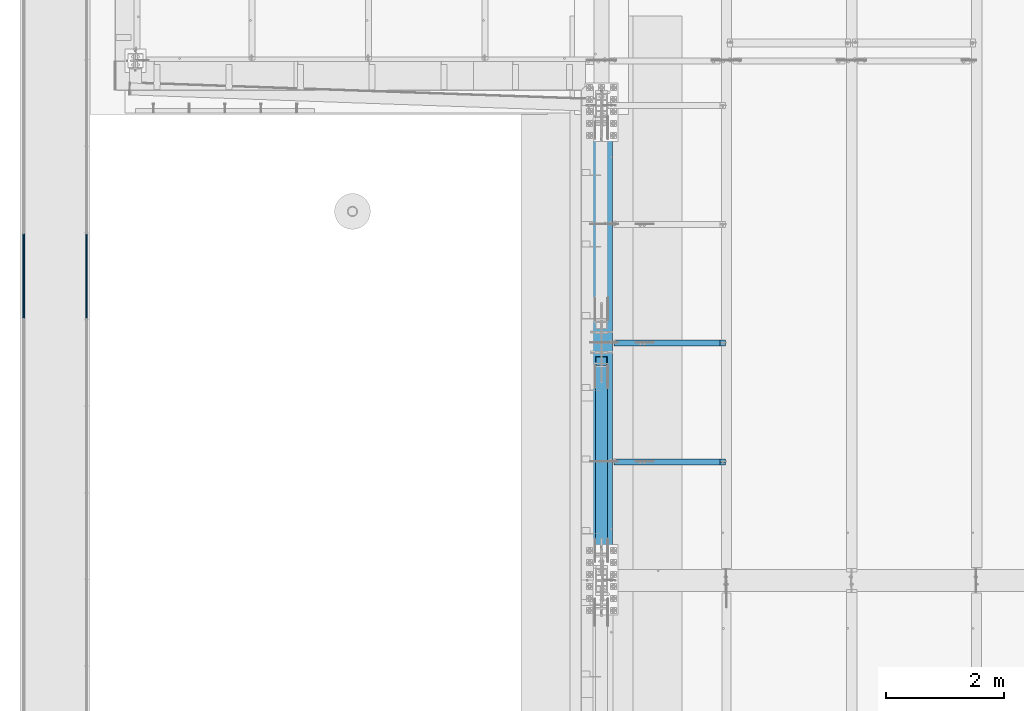
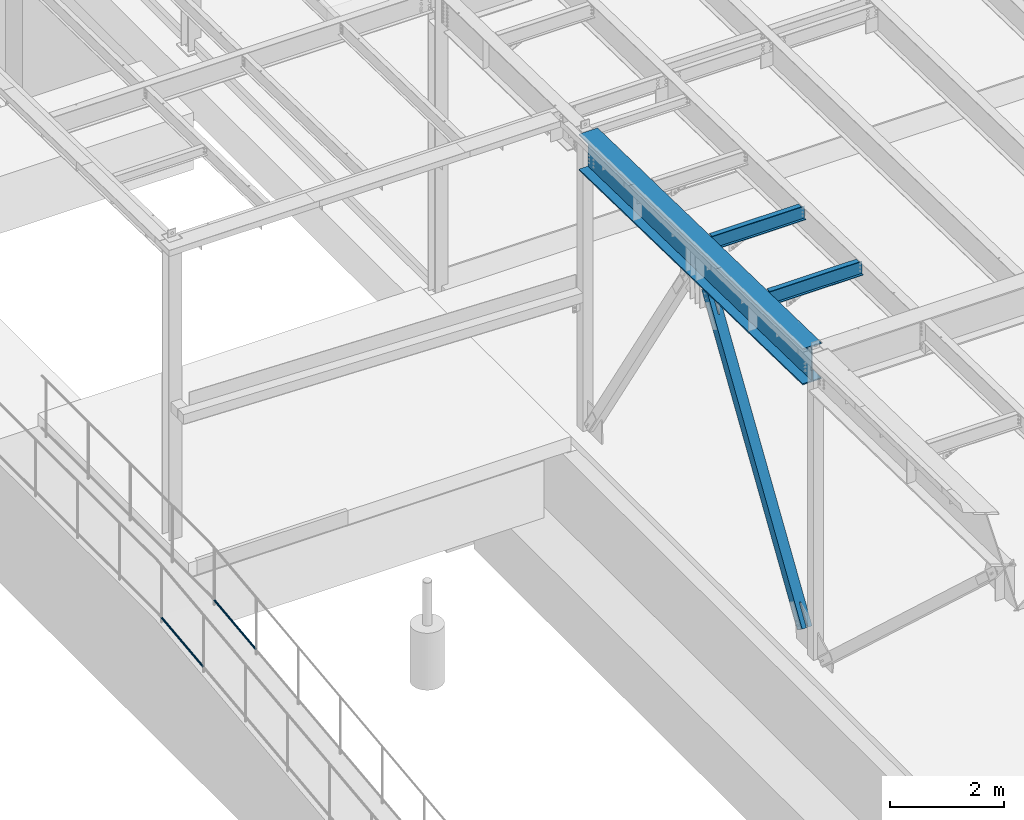
# One storey, part 1044 of 1763: 5 beams, 1 member, 6 elements without a shape of their own.
"""IFC2X3 building model written with IfcOpenShell, lengths in millimetres."""

from ifc_helpers import new_model, si_unit, frame, origin_with_axes, place, context, subcontext, project, spatial, faceted_brep, material, type_object, element, aggregate, save


model = new_model("IFC2X3")

# Units and contexts
model_context = context("Model", 3, precision=1e-05, world=origin_with_axes())
body_context = subcontext(model_context, "Body", "Model", "MODEL_VIEW")
ifc_project = project(units=[si_unit("LENGTHUNIT", "METRE", prefix="MILLI"), si_unit("AREAUNIT", "SQUARE_METRE"), si_unit("VOLUMEUNIT", "CUBIC_METRE"), si_unit("MASSUNIT", "GRAM", prefix="KILO"), si_unit("TIMEUNIT", "SECOND"), si_unit("PLANEANGLEUNIT", "RADIAN"), si_unit("SOLIDANGLEUNIT", "STERADIAN"), si_unit("THERMODYNAMICTEMPERATUREUNIT", "DEGREE_CELSIUS"), si_unit("LUMINOUSINTENSITYUNIT", "LUMEN")], contexts=[model_context])

# Site, building, storey
site_placement = place(None, origin_with_axes())
site = spatial("IfcSite", under=ifc_project, at=site_placement, CompositionType="ELEMENT")
building_placement = place(site_placement, origin_with_axes())
building = spatial("IfcBuilding", under=site, at=building_placement, Name="Undefined", CompositionType="ELEMENT")
storey_placement = place(building_placement, origin_with_axes())
storey = spatial("IfcBuildingStorey", under=building, at=storey_placement, Name="Undefined", CompositionType="ELEMENT", Elevation=0.0)

# Assembly, beam
assembly_1_placement = place(storey_placement, origin_with_axes())
assembly_1 = element("IfcElementAssembly", 1, at=assembly_1_placement, inside=storey, Name="GUARDRAIL", AssemblyPlace="NOTDEFINED", PredefinedType="RIGID_FRAME")
ifc_material_1 = material(Name="STEEL/A513")
beam_type_1 = type_object("IfcBeamType", PredefinedType="NOTDEFINED")
beam_1_placement = place(assembly_1_placement, frame((-97200.6527017878, 4895.63786635489, 5845.27590391864), z_axis=(0.0, -0.114062593029902, 0.993473565260443), x_axis=(0.0, 0.993473565260443, 0.114062593029902)))
beam_1 = element("IfcBeam", 2, at=beam_1_placement, type_object=beam_type_1, material=ifc_material_1, Name="GUARDRAIL", context=body_context, shape_type="Brep", body=[
    faceted_brep([(1468.16665642951, -9.52499999999418, 16.4977839425555), (1467.58900470802, -9.52499999999418, 11.4667123804174), (1467.30376971339, -7.68349999999919, 13.3082123804179), (1465.46783960526, 0.0, 15.3670000004613), (1465.89071001447, 0.0, 19.0500000004622), (1467.3037697134, 7.68349999999919, 13.308212380417), (1467.58900470802, 9.52499999999418, 11.4667123804174), (1468.16665642951, 9.52499999999418, 16.4977839425555), (1482.87860532686, 19.0500000000029, 4.66570782009512e-10), (1474.38465767071, 16.4977839420899, 9.52500000046439), (1472.19739693342, 16.4977839420899, -9.52499999953761), (1470.96269582906, 13.3082123799541, 7.68350000046303), (1472.15281425492, 15.3669999999984, 4.6293280320242e-10), (1469.19830550098, 13.3082123799541, -7.68349999953807), (1464.95586142462, 9.52499999999418, -11.4667123794952), (1464.37820970313, 9.52499999999418, -16.4977839416342), (1464.24775602078, 7.68349999999919, -13.3082123794957), (1461.9390589491, 0.0, -15.3669999995409), (1461.51618853989, 0.0, -19.0499999995409), (1464.95586142462, -9.52499999999418, -11.4667123794952), (1464.37820970313, -9.52499999999418, -16.4977839416342), (1464.24775602078, -7.68349999999919, -13.3082123794948), (1482.87860532695, -19.0500000000029, 4.55656845588237e-10), (1472.19739693342, -16.4977839420899, -9.52499999953761), (1474.38465767071, -16.4977839420899, 9.52500000046439), (1469.19830550097, -13.3082123799541, -7.68349999953807), (1472.15281425491, -15.3669999999984, 4.6293280320242e-10), (1470.96269582905, -13.3082123799541, 7.68350000046303), (8.49463121237, -16.4977839420899, -9.52499999999782), (14.7126324911599, -9.52499999999418, -16.4977839420899), (0.00068350478454704, 19.0500000000029, 0.0), (8.49463121237, 16.4977839420899, -9.52499999999782), (10.6818918337324, 16.4977839420899, 9.52500000000418), (18.5010790167537, 9.52499999999418, 16.4977839421008), (21.3631001626848, 0.0, 19.0500000000075), (14.7126324911599, 9.52499999999418, -16.4977839420899), (16.9885789199607, 0.0, -19.0499999999956), (17.4114493067575, 0.0, -15.3669999999956), (15.2902841820321, -9.52499999999418, -11.4667123799509), (15.575519187561, -7.68349999999919, -13.3082123799513), (15.575519187561, 7.68349999999919, -13.3082123799513), (15.2902841820321, 9.52499999999418, -11.4667123799509), (11.9165930406441, 13.3082123799541, -7.68349999999646), (10.7264745694495, 15.3669999999984, 4.54747350886464e-12), (13.6809832752053, 13.3082123799541, 7.68350000000555), (17.923427325881, 9.52499999999418, 11.4667123799609), (18.631532718199, 7.68349999999919, 13.3082123799622), (20.9402297758882, 0.0, 15.3670000000075), (18.631532718199, -7.68349999999919, 13.3082123799622), (17.923427325881, -9.52499999999418, 11.4667123799609), (18.5010790167537, -9.52499999999418, 16.4977839421008), (10.6818918337324, -16.4977839420899, 9.52500000000418), (0.00068350478454704, -19.0500000000029, 0.0), (13.6809832752053, -13.3082123799541, 7.68350000000555), (10.7264745694495, -15.3669999999984, 4.54747350886464e-12), (11.9165930406441, -13.3082123799541, -7.68349999999646)], [[[0, 1, 2, 3, 4]], [[4, 3, 5, 6, 7]], [[8, 9, 10]], [[7, 6, 11, 12, 13, 14, 15, 10, 9]], [[16, 17, 18, 15, 14]], [[19, 20, 18, 17, 21]], [[22, 23, 24]], [[24, 23, 20, 19, 25, 26, 27, 1, 0]], [[28, 29, 20, 23]], [[30, 31, 32]], [[33, 34, 4, 7]], [[32, 33, 7, 9]], [[30, 32, 9, 8]], [[31, 30, 8, 10]], [[35, 31, 10, 15]], [[36, 35, 15, 18]], [[29, 36, 18, 20]], [[37, 36, 29, 38, 39]], [[40, 41, 35, 36, 37]], [[32, 31, 35, 41, 42, 43, 44, 45, 33]], [[33, 45, 46, 47, 34]], [[34, 47, 48, 49, 50]], [[34, 50, 0, 4]], [[50, 51, 24, 0]], [[51, 52, 22, 24]], [[52, 28, 23, 22]], [[51, 28, 52]], [[50, 49, 53, 54, 55, 38, 29, 28, 51]], [[55, 54, 26, 25]], [[21, 39, 38, 55, 25, 19]], [[37, 39, 21, 17]], [[40, 37, 17, 16]], [[42, 41, 40, 16, 14, 13]], [[43, 42, 13, 12]], [[44, 43, 12, 11]], [[5, 46, 45, 44, 11, 6]], [[47, 46, 5, 3]], [[48, 47, 3, 2]], [[53, 49, 48, 2, 1, 27]], [[54, 53, 27, 26]]]),
])
aggregate(assembly_1, [beam_1])

assembly_2_placement = place(storey_placement, origin_with_axes())
assembly_2 = element("IfcElementAssembly", 3, at=assembly_2_placement, inside=storey, Name="GUARDRAIL", AssemblyPlace="NOTDEFINED", PredefinedType="RIGID_FRAME")
beam_2_placement = place(assembly_2_placement, frame((-96133.8527017878, 4895.63786635489, 5845.27590391864), z_axis=(0.0, -0.114062593029902, 0.993473565260443), x_axis=(0.0, 0.993473565260443, 0.114062593029902)))
beam_2 = element("IfcBeam", 4, at=beam_2_placement, type_object=beam_type_1, material=ifc_material_1, Name="GUARDRAIL", context=body_context, shape_type="Brep", body=[
    faceted_brep([(1468.16665642951, -9.52499999999418, 16.4977839425555), (1467.58900470802, -9.52499999999418, 11.4667123804174), (1467.30376971339, -7.68349999999919, 13.3082123804179), (1465.46783960526, 0.0, 15.3670000004613), (1465.89071001447, 0.0, 19.0500000004622), (1467.3037697134, 7.68349999999919, 13.308212380417), (1467.58900470802, 9.52499999999418, 11.4667123804174), (1468.16665642951, 9.52499999999418, 16.4977839425555), (1482.87860532686, 19.0500000000029, 4.66570782009512e-10), (1474.38465767071, 16.4977839420899, 9.52500000046439), (1472.19739693342, 16.4977839420899, -9.52499999953761), (1470.96269582906, 13.3082123799541, 7.68350000046303), (1472.15281425492, 15.3669999999984, 4.6293280320242e-10), (1469.19830550098, 13.3082123799541, -7.68349999953807), (1464.95586142462, 9.52499999999418, -11.4667123794952), (1464.37820970313, 9.52499999999418, -16.4977839416342), (1464.24775602078, 7.68349999999919, -13.3082123794957), (1461.9390589491, 0.0, -15.3669999995409), (1461.51618853989, 0.0, -19.0499999995409), (1464.95586142462, -9.52499999999418, -11.4667123794952), (1464.37820970313, -9.52499999999418, -16.4977839416342), (1464.24775602078, -7.68349999999919, -13.3082123794948), (1482.87860532695, -19.0500000000029, 4.55656845588237e-10), (1472.19739693342, -16.4977839420899, -9.52499999953761), (1474.38465767071, -16.4977839420899, 9.52500000046439), (1469.19830550097, -13.3082123799541, -7.68349999953807), (1472.15281425491, -15.3669999999984, 4.6293280320242e-10), (1470.96269582905, -13.3082123799541, 7.68350000046303), (8.49463121237, -16.4977839420899, -9.52499999999782), (14.7126324911599, -9.52499999999418, -16.4977839420899), (0.00068350478454704, 19.0500000000029, 0.0), (8.49463121237, 16.4977839420899, -9.52499999999782), (10.6818918337324, 16.4977839420899, 9.52500000000418), (18.5010790167537, 9.52499999999418, 16.4977839421008), (21.3631001626848, 0.0, 19.0500000000075), (14.7126324911599, 9.52499999999418, -16.4977839420899), (16.9885789199607, 0.0, -19.0499999999956), (17.4114493067575, 0.0, -15.3669999999956), (15.2902841820321, -9.52499999999418, -11.4667123799509), (15.575519187561, -7.68349999999919, -13.3082123799513), (15.575519187561, 7.68349999999919, -13.3082123799513), (15.2902841820321, 9.52499999999418, -11.4667123799509), (11.9165930406441, 13.3082123799541, -7.68349999999646), (10.7264745694495, 15.3669999999984, 4.54747350886464e-12), (13.6809832752053, 13.3082123799541, 7.68350000000555), (17.923427325881, 9.52499999999418, 11.4667123799609), (18.631532718199, 7.68349999999919, 13.3082123799622), (20.9402297758882, 0.0, 15.3670000000075), (18.631532718199, -7.68349999999919, 13.3082123799622), (17.923427325881, -9.52499999999418, 11.4667123799609), (18.5010790167537, -9.52499999999418, 16.4977839421008), (10.6818918337324, -16.4977839420899, 9.52500000000418), (0.00068350478454704, -19.0500000000029, 0.0), (13.6809832752053, -13.3082123799541, 7.68350000000555), (10.7264745694495, -15.3669999999984, 4.54747350886464e-12), (11.9165930406441, -13.3082123799541, -7.68349999999646)], [[[0, 1, 2, 3, 4]], [[4, 3, 5, 6, 7]], [[8, 9, 10]], [[7, 6, 11, 12, 13, 14, 15, 10, 9]], [[16, 17, 18, 15, 14]], [[19, 20, 18, 17, 21]], [[22, 23, 24]], [[24, 23, 20, 19, 25, 26, 27, 1, 0]], [[28, 29, 20, 23]], [[30, 31, 32]], [[33, 34, 4, 7]], [[32, 33, 7, 9]], [[30, 32, 9, 8]], [[31, 30, 8, 10]], [[35, 31, 10, 15]], [[36, 35, 15, 18]], [[29, 36, 18, 20]], [[37, 36, 29, 38, 39]], [[40, 41, 35, 36, 37]], [[32, 31, 35, 41, 42, 43, 44, 45, 33]], [[33, 45, 46, 47, 34]], [[34, 47, 48, 49, 50]], [[34, 50, 0, 4]], [[50, 51, 24, 0]], [[51, 52, 22, 24]], [[52, 28, 23, 22]], [[51, 28, 52]], [[50, 49, 53, 54, 55, 38, 29, 28, 51]], [[55, 54, 26, 25]], [[21, 39, 38, 55, 25, 19]], [[37, 39, 21, 17]], [[40, 37, 17, 16]], [[42, 41, 40, 16, 14, 13]], [[43, 42, 13, 12]], [[44, 43, 12, 11]], [[5, 46, 45, 44, 11, 6]], [[47, 46, 5, 3]], [[48, 47, 3, 2]], [[53, 49, 48, 2, 1, 27]], [[54, 53, 27, 26]]]),
])
aggregate(assembly_2, [beam_2])

assembly_3_placement = place(storey_placement, origin_with_axes())
assembly_3 = element("IfcElementAssembly", 5, at=assembly_3_placement, inside=storey, Name="BEAM", AssemblyPlace="NOTDEFINED", PredefinedType="RIGID_FRAME")
ifc_material_2 = material(Name="STEEL/A992")
beam_type_2 = type_object("IfcBeamType", Name="W12X22", PredefinedType="NOTDEFINED")
beam_3_placement = place(assembly_3_placement, frame((-87375.4372736983, 4495.79999998664, 11668.3905106838), z_axis=(0.0, 0.0, 1.0), x_axis=(1.0, 0.0, 0.0)))
beam_3 = element("IfcBeam", 6, at=beam_3_placement, type_object=beam_type_2, material=ifc_material_2, Name="BEAM", ObjectType="W12X22", context=body_context, shape_type="Brep", body=[
    faceted_brep([(20.6374999999971, -3.17499999999927, -123.824999999781), (20.6374999999971, 3.17499999999927, -123.824999999781), (198.437500190732, 3.17500001932785, -123.824999999781), (198.437500190732, -3.17500000000018, -123.824999999781), (203.297579708771, 3.17500001940971, -124.791729922368), (203.297579708771, -3.17500000000018, -124.791729922368), (207.417756176932, 3.17500001964163, -127.544743822846), (207.417756176932, -3.17500000000018, -127.544743822846), (210.170770077413, 3.17500001998906, -131.664920290999), (210.170770077413, -3.17500000000018, -131.664920290999), (211.137499999997, -3.17500000000018, -136.524999809046), (211.137499999997, 3.17500002039924, -136.524999809046), (211.137499999997, 3.17500004775593, -144.4625), (211.137499999997, 50.8000000000002, -144.4625), (211.137499999997, 50.8000000000002, -155.575000000001), (211.137499999997, -50.8000000000002, -155.575000000001), (211.137499999997, -50.8000000000002, -144.4625), (211.137499999997, -3.17500000000018, -144.4625), (2019.98035714286, 50.7999999999993, 144.4625), (2019.98035714286, 3.17499999999927, 144.4625), (211.137499999997, 3.17500000000018, 144.4625), (211.137499999997, 50.8000000000002, 144.4625), (198.437500190732, -3.17500000000018, 111.12500000022), (198.437500190732, 3.17499999968732, 111.12500000022), (20.6374999999971, 3.17499999999927, 111.12500000022), (20.6374999999971, -3.17499999999927, 111.12500000022), (203.297579708771, -3.17500000000018, 112.091729922808), (203.297579708771, 3.17499999960637, 112.091729922808), (207.417756176932, -3.17500000000018, 114.844743823285), (207.417756176932, 3.17499999937718, 114.844743823285), (210.170770077413, -3.17500000000018, 118.964920291439), (210.170770077413, 3.1749999990343, 118.964920291439), (211.137499999997, -3.17500000000018, 123.824999809485), (211.137499999997, 3.17499999862866, 123.824999809485), (2019.98035714286, -50.7999999999993, 155.575000000001), (2019.98035714286, 50.7999999999993, 155.575000000001), (211.137499999997, 50.8000000000002, 155.575000000001), (211.137499999997, -50.8000000000002, 155.575000000001), (2019.98035714286, -50.7999999999993, 144.4625), (211.137499999997, -50.8000000000002, 144.4625), (2019.98035714286, -3.17499999999927, 144.4625), (211.137499999997, -3.17500000000018, 144.4625), (2019.98035714286, -3.17499999999927, 129.915001480787), (2019.98035714286, 3.17499999999927, 129.915001480787), (2020.94708706545, -3.17499999999927, 125.054921962741), (2020.94708706545, 3.17499999999927, 125.054921962741), (2023.70010096593, -3.17499999999927, 120.934745494587), (2023.70010096593, 3.17499999999927, 120.934745494587), (2027.82027743409, -3.17499999999927, 118.18173159411), (2027.82027743409, 3.17499999999927, 118.18173159411), (2032.68035695213, -3.17499999999927, 117.215001671522), (2032.68035695213, 3.17499999999927, 117.215001671522), (2108.88035714286, -3.17499999999927, 117.215001671522), (2108.88035714286, 3.17499999999927, 117.215001671522), (2108.88035714286, -3.17499999999927, -144.4625), (2108.88035714286, -50.7999999999993, -144.4625), (2108.88035714286, -50.7999999999993, -155.575000000001), (2108.88035714286, 50.7999999999993, -155.575000000001), (2108.88035714286, 50.7999999999993, -144.4625), (2108.88035714286, 3.17499999999927, -144.4625)], [[[0, 1, 2, 3]], [[3, 2, 4, 5]], [[5, 4, 6, 7]], [[7, 6, 8, 9]], [[10, 11, 12, 13, 14, 15, 16, 17]], [[9, 8, 11, 10]], [[18, 19, 20, 21]], [[22, 23, 24, 25]], [[26, 27, 23, 22]], [[28, 29, 27, 26]], [[30, 31, 29, 28]], [[32, 33, 31, 30]], [[34, 35, 36, 37]], [[38, 34, 37, 39]], [[40, 38, 39, 41]], [[37, 36, 21, 20, 33, 32, 41, 39]], [[35, 18, 21, 36]], [[34, 38, 40, 42, 43, 19, 18, 35]], [[44, 45, 43, 42]], [[46, 47, 45, 44]], [[48, 49, 47, 46]], [[50, 51, 49, 48]], [[52, 53, 51, 50]], [[54, 55, 56, 57, 58, 59, 53, 52]], [[55, 54, 17, 16]], [[56, 55, 16, 15]], [[57, 56, 15, 14]], [[58, 57, 14, 13]], [[59, 58, 13, 12]], [[6, 4, 2, 1, 24, 23, 27, 29, 31, 33, 20, 19, 43, 45, 47, 49, 51, 53, 59, 12, 11, 8]], [[25, 24, 1, 0]], [[54, 52, 50, 48, 46, 44, 42, 40, 41, 32, 30, 28, 26, 22, 25, 0, 3, 5, 7, 9, 10, 17]]]),
])
aggregate(assembly_3, [beam_3])

assembly_4_placement = place(storey_placement, origin_with_axes())
assembly_4 = element("IfcElementAssembly", 7, at=assembly_4_placement, inside=storey, Name="BEAM", AssemblyPlace="NOTDEFINED", PredefinedType="RIGID_FRAME")
beam_4_placement = place(assembly_4_placement, frame((-87375.4372736983, 2476.49999998663, 11710.6058410897), z_axis=(0.0, 0.0, 1.0), x_axis=(1.0, 0.0, 0.0)))
beam_4 = element("IfcBeam", 8, at=beam_4_placement, type_object=beam_type_2, material=ifc_material_2, Name="BEAM", ObjectType="W12X22", context=body_context, shape_type="Brep", body=[
    faceted_brep([(20.6374999999971, -3.17499999999927, -123.824999999781), (20.6374999999971, 3.17499999999927, -123.824999999781), (198.437500190732, 3.17500001932785, -123.824999999781), (198.437500190732, -3.17500000000018, -123.824999999781), (203.297579708771, 3.17500001940971, -124.791729922368), (203.297579708771, -3.17500000000018, -124.791729922368), (207.417756176932, 3.17500001964163, -127.544743822846), (207.417756176932, -3.17500000000018, -127.544743822846), (210.170770077413, 3.17500001998906, -131.664920290999), (210.170770077413, -3.17500000000018, -131.664920290999), (211.137499999997, -3.17500000000018, -136.524999809046), (211.137499999997, 3.17500002039924, -136.524999809046), (211.137499999997, 3.17500004775593, -144.4625), (211.137499999997, 50.8000000000002, -144.4625), (211.137499999997, 50.8000000000002, -155.575000000001), (211.137499999997, -50.8000000000002, -155.575000000001), (211.137499999997, -50.8000000000002, -144.4625), (211.137499999997, -3.17500000000018, -144.4625), (2019.98035714286, 50.7999999999993, 144.4625), (2019.98035714286, 3.17499999999927, 144.4625), (211.137499999997, 3.17500000000018, 144.4625), (211.137499999997, 50.8000000000002, 144.4625), (198.437500190732, -3.17500000000018, 111.12500000022), (198.437500190732, 3.17499999968732, 111.12500000022), (20.6374999999971, 3.17499999999927, 111.12500000022), (20.6374999999971, -3.17499999999927, 111.12500000022), (203.297579708771, -3.17500000000018, 112.091729922808), (203.297579708771, 3.17499999960637, 112.091729922808), (207.417756176932, -3.17500000000018, 114.844743823285), (207.417756176932, 3.17499999937718, 114.844743823285), (210.170770077413, -3.17500000000018, 118.964920291439), (210.170770077413, 3.1749999990343, 118.964920291439), (211.137499999997, -3.17500000000018, 123.824999809485), (211.137499999997, 3.17499999862866, 123.824999809485), (2019.98035714286, -50.7999999999993, 155.575000000001), (2019.98035714286, 50.7999999999993, 155.575000000001), (211.137499999997, 50.8000000000002, 155.575000000001), (211.137499999997, -50.8000000000002, 155.575000000001), (2019.98035714286, -50.7999999999993, 144.4625), (211.137499999997, -50.8000000000002, 144.4625), (2019.98035714286, -3.17499999999927, 144.4625), (211.137499999997, -3.17500000000018, 144.4625), (2019.98035714286, -3.17499999999927, 129.915001480787), (2019.98035714286, 3.17499999999927, 129.915001480787), (2020.94708706545, -3.17499999999927, 125.054921962741), (2020.94708706545, 3.17499999999927, 125.054921962741), (2023.70010096593, -3.17499999999927, 120.934745494587), (2023.70010096593, 3.17499999999927, 120.934745494587), (2027.82027743409, -3.17499999999927, 118.18173159411), (2027.82027743409, 3.17499999999927, 118.18173159411), (2032.68035695213, -3.17499999999927, 117.215001671522), (2032.68035695213, 3.17499999999927, 117.215001671522), (2108.88035714286, -3.17499999999927, 117.215001671522), (2108.88035714286, 3.17499999999927, 117.215001671522), (2108.88035714286, -3.17499999999927, -144.4625), (2108.88035714286, -50.7999999999993, -144.4625), (2108.88035714286, -50.7999999999993, -155.575000000001), (2108.88035714286, 50.7999999999993, -155.575000000001), (2108.88035714286, 50.7999999999993, -144.4625), (2108.88035714286, 3.17499999999927, -144.4625)], [[[0, 1, 2, 3]], [[3, 2, 4, 5]], [[5, 4, 6, 7]], [[7, 6, 8, 9]], [[10, 11, 12, 13, 14, 15, 16, 17]], [[9, 8, 11, 10]], [[18, 19, 20, 21]], [[22, 23, 24, 25]], [[26, 27, 23, 22]], [[28, 29, 27, 26]], [[30, 31, 29, 28]], [[32, 33, 31, 30]], [[34, 35, 36, 37]], [[38, 34, 37, 39]], [[40, 38, 39, 41]], [[37, 36, 21, 20, 33, 32, 41, 39]], [[35, 18, 21, 36]], [[34, 38, 40, 42, 43, 19, 18, 35]], [[44, 45, 43, 42]], [[46, 47, 45, 44]], [[48, 49, 47, 46]], [[50, 51, 49, 48]], [[52, 53, 51, 50]], [[54, 55, 56, 57, 58, 59, 53, 52]], [[55, 54, 17, 16]], [[56, 55, 16, 15]], [[57, 56, 15, 14]], [[58, 57, 14, 13]], [[59, 58, 13, 12]], [[6, 4, 2, 1, 24, 23, 27, 29, 31, 33, 20, 19, 43, 45, 47, 49, 51, 53, 59, 12, 11, 8]], [[25, 24, 1, 0]], [[54, 52, 50, 48, 46, 44, 42, 40, 41, 32, 30, 28, 26, 22, 25, 0, 3, 5, 7, 9, 10, 17]]]),
])
aggregate(assembly_4, [beam_4])

assembly_5_placement = place(storey_placement, origin_with_axes())
assembly_5 = element("IfcElementAssembly", 9, at=assembly_5_placement, inside=storey, Name="BEAM", AssemblyPlace="NOTDEFINED", PredefinedType="RIGID_FRAME")
beam_type_3 = type_object("IfcBeamType", Name="W30X173", PredefinedType="NOTDEFINED")
beam_5_placement = place(assembly_5_placement, frame((-87375.4372736983, 449.103859811119, 11521.1307908923), z_axis=(0.0, 0.0209013539966291, 0.999781542838788), x_axis=(0.0, 0.999781542776098, -0.0209013569953182)))
beam_5 = element("IfcBeam", 10, at=beam_5_placement, type_object=beam_type_3, material=ifc_material_2, Name="BEAM", ObjectType="W30X173", context=body_context, shape_type="Brep", body=[
    faceted_brep([(130.520793641485, 190.5, -387.350000000353), (129.956595043292, 190.5, -360.36250000033), (7980.27155289183, 190.5, -360.362500003046), (7980.83575149002, 190.5, -387.350000003069), (129.956595043292, 7.9375, -360.36250000033), (7980.27155289183, 7.9375, -360.362500003046), (114.889173656273, 7.9375, 360.362500000247), (7965.20413150481, 7.9375, 360.362499997533), (114.889173656273, 190.5, 360.362500000247), (7965.20413150481, 190.5, 360.362499997533), (114.32497505808, 190.5, 387.35000000027), (7964.63993290662, 190.5, 387.349999997554), (114.32497505808, -190.5, 387.35000000027), (7964.63993290662, -190.5, 387.349999997554), (114.889173656273, -190.5, 360.362500000247), (7965.20413150481, -190.5, 360.362499997533), (114.889173656273, -7.9375, 360.362500000247), (7965.20413150481, -7.9375, 360.362499997533), (129.956595043292, -7.9375, -360.36250000033), (7980.27155289183, -7.9375, -360.362500003046), (129.956595043292, -190.5, -360.36250000033), (7980.27155289183, -190.5, -360.362500003046), (130.520793641485, -190.5, -387.350000000353), (7980.83575149002, -190.5, -387.350000003069)], [[[0, 1, 2, 3]], [[1, 4, 5, 2]], [[4, 6, 7, 5]], [[6, 8, 9, 7]], [[8, 10, 11, 9]], [[10, 12, 13, 11]], [[12, 14, 15, 13]], [[14, 16, 17, 15]], [[16, 18, 19, 17]], [[18, 20, 21, 19]], [[20, 22, 23, 21]], [[22, 0, 3, 23]], [[5, 7, 9, 11, 13, 15, 17, 19, 21, 23, 3, 2]], [[22, 20, 18, 16, 14, 12, 10, 8, 6, 4, 1, 0]]]),
])
aggregate(assembly_5, [beam_5])

# Assembly, member
assembly_6_placement = place(storey_placement, origin_with_axes())
assembly_6 = element("IfcElementAssembly", 11, at=assembly_6_placement, inside=storey, Name="V. BRACE", AssemblyPlace="NOTDEFINED", PredefinedType="RIGID_FRAME")
ifc_material_3 = material()
member_type = type_object("IfcMemberType", Name="HSS8X8X1/2", PredefinedType="NOTDEFINED")
member_placement = place(assembly_6_placement, frame((-87375.4372736983, 457.200000000009, 5130.79999999998), z_axis=(0.0, -0.842093564139254, 0.539331465089187), x_axis=(0.0, 0.539331465089187, 0.842093564139254)))
member = element("IfcMember", 12, at=member_placement, type_object=member_type, material=ifc_material_3, Name="V. BRACE", ObjectType="HSS8X8X1/2", context=body_context, shape_type="Brep", body=[
    faceted_brep([(6912.49603849785, 11.112500381525, 101.599999998635), (6429.89602102694, 11.112500381525, 101.599999998731), (6429.89602102693, 11.112500381525, 88.8999999987313), (6912.49603849786, 11.112500381525, 88.8999999986368), (6426.25096147965, 10.3874529577297, 101.599999998731), (6426.25096147964, 10.3874529577297, 88.8999999987318), (6423.16082920588, 8.32269258405722, 101.599999998732), (6423.16082920587, 8.32269258405722, 88.8999999987327), (6421.09606883221, 5.2325603102945, 101.599999998732), (6421.0960688322, 5.2325603102945, 88.8999999987332), (6420.37102140842, 1.58750076299475, 101.599999998734), (6420.37102140841, 1.58750076299475, 88.8999999987332), (6420.37102140842, -1.58750038141443, 101.599999998734), (6420.37102140841, -1.58750038141443, 88.8999999987332), (6421.09606883221, -5.23255992871418, 101.599999998732), (6421.0960688322, -5.23255992871418, 88.8999999987332), (6423.16082920588, -8.3226922024769, 101.599999998732), (6423.16082920587, -8.3226922024769, 88.8999999987327), (6426.25096147965, -10.3874525761494, 101.599999998731), (6426.25096147964, -10.3874525761494, 88.8999999987318), (6429.89602102694, -11.1124999999447, 101.599999998731), (6429.89602102693, -11.1124999999447, 88.8999999987313), (6912.49603849785, -11.1124999999447, 101.599999998635), (6912.49603849786, -11.1124999999447, 88.8999999986368), (6912.49603849789, 11.112500381525, -88.9000000013607), (6429.89602102679, 11.112500381525, -88.9000000012661), (6429.89602102678, 11.112500381525, -101.600000001266), (6912.4960384979, 11.112500381525, -101.600000001362), (6426.2509614795, 10.3874529577297, -88.9000000012652), (6426.25096147949, 10.3874529577297, -101.600000001265), (6423.16082920574, 8.32269258405722, -88.9000000012647), (6423.16082920573, 8.32269258405722, -101.600000001265), (6421.09606883206, 5.2325603102945, -88.9000000012643), (6421.09606883206, 5.2325603102945, -101.600000001264), (6420.37102140827, 1.58750076299475, -88.9000000012638), (6420.37102140826, 1.58750076299475, -101.600000001264), (6420.37102140827, -1.58750038141443, -88.9000000012638), (6420.37102140826, -1.58750038141443, -101.600000001264), (6421.09606883206, -5.23255992871418, -88.9000000012643), (6421.09606883206, -5.23255992871418, -101.600000001264), (6423.16082920574, -8.3226922024769, -88.9000000012647), (6423.16082920573, -8.3226922024769, -101.600000001265), (6426.2509614795, -10.3874525761494, -88.9000000012652), (6426.25096147949, -10.3874525761494, -101.600000001265), (6429.89602102679, -11.1124999999447, -88.9000000012661), (6429.89602102678, -11.1124999999447, -101.600000001266), (6912.49603849789, -11.1124999999447, -88.9000000013607), (6912.4960384979, -11.1124999999447, -101.600000001362), (692.136710207879, 88.8999999999942, 88.8999999998623), (692.136710207917, 88.8999999999942, -88.9000000001347), (6912.49603849789, 88.8999999999942, -88.9000000013607), (6912.49603849786, 88.8999999999942, 88.8999999986368), (6912.49603849786, -88.8999999999942, 88.8999999986368), (692.136710207879, -88.8999999999942, 88.8999999998623), (692.136710207879, -14.2874999999622, 88.8999999998623), (1149.33671210502, -14.2874999999331, 88.8999999997723), (1154.19679162306, -13.3207700773492, 88.8999999997714), (1158.3169680912, -10.567756176868, 88.8999999997704), (1161.06998199168, -6.44757970870705, 88.89999999977), (1162.03671191427, -1.58750019066792, 88.8999999997695), (1162.03671191427, 1.58750095371215, 88.8999999997695), (1161.06998199168, 6.44758047175128, 88.89999999977), (1158.3169680912, 10.5677569399122, 88.8999999997704), (1154.19679162306, 13.3207708403934, 88.8999999997714), (1149.33671210501, 14.2875007629773, 88.8999999997723), (692.136710207879, 14.2875007629773, 88.8999999998623), (692.136710207917, -88.8999999999942, -88.9000000001347), (6912.49603849789, -88.8999999999942, -88.9000000013607), (692.136710207917, 14.2875007629773, -88.9000000001347), (1149.33671210506, 14.2875007629773, -88.9000000002243), (1154.1967916231, 13.3207708403934, -88.9000000002252), (1158.31696809125, 10.5677569399122, -88.9000000002266), (1161.06998199173, 6.44758047175128, -88.900000000227), (1162.03671191431, 1.58750095371215, -88.9000000002266), (1162.03671191431, -1.58750019066792, -88.9000000002266), (1161.06998199173, -6.44757970870705, -88.900000000227), (1158.31696809125, -10.567756176868, -88.9000000002261), (1154.1967916231, -13.3207700773492, -88.9000000002256), (1149.33671210506, -14.2874999999331, -88.9000000002247), (692.136710207917, -14.2874999999622, -88.9000000001347), (692.136710207919, 14.2875007629773, -101.600000000134), (1149.33671210506, 14.2875007629773, -101.600000000224), (1154.1967916231, 13.3207708403934, -101.600000000225), (1158.31696809125, 10.5677569399122, -101.600000000226), (1161.06998199173, 6.44758047175128, -101.600000000226), (1162.03671191432, 1.58750095371215, -101.600000000227), (1162.03671191432, -1.58750019066792, -101.600000000227), (1161.06998199173, -6.44757970870705, -101.600000000227), (1158.31696809125, -10.567756176868, -101.600000000226), (1154.1967916231, -13.3207700773492, -101.600000000225), (1149.33671210507, -14.2874999999331, -101.600000000224), (692.136710207919, -14.2874999999622, -101.600000000134), (692.136710207919, -101.600000000006, -101.600000000134), (692.136710207876, -101.600000000006, 101.599999999862), (692.136710207876, -14.2874999999622, 101.599999999862), (1149.33671210501, -14.2874999999331, 101.599999999772), (1154.19679162305, -13.3207700773492, 101.599999999771), (1158.3169680912, -10.567756176868, 101.59999999977), (1161.06998199168, -6.44757970870705, 101.599999999769), (1162.03671191426, -1.58750019066792, 101.599999999769), (1162.03671191426, 1.58750095371215, 101.599999999769), (1161.06998199168, 6.44758047175128, 101.599999999769), (1158.3169680912, 10.5677569399122, 101.59999999977), (1154.19679162305, 13.3207708403934, 101.599999999771), (1149.33671210501, 14.2875007629773, 101.599999999772), (692.136710207876, 14.2875007629773, 101.599999999862), (692.136710207876, 101.600000000006, 101.599999999862), (692.136710207919, 101.600000000006, -101.600000000134), (6912.49603849785, 101.600000000006, 101.599999998635), (6912.4960384979, 101.600000000006, -101.600000001362), (6912.4960384979, -101.600000000006, -101.600000001362), (6912.49603849785, -101.600000000006, 101.599999998635)], [[[0, 1, 2, 3]], [[4, 5, 2, 1]], [[6, 7, 5, 4]], [[8, 9, 7, 6]], [[10, 11, 9, 8]], [[12, 13, 11, 10]], [[14, 15, 13, 12]], [[16, 17, 15, 14]], [[18, 19, 17, 16]], [[20, 21, 19, 18]], [[22, 23, 21, 20]], [[24, 25, 26, 27]], [[28, 29, 26, 25]], [[30, 31, 29, 28]], [[32, 33, 31, 30]], [[34, 35, 33, 32]], [[36, 37, 35, 34]], [[38, 39, 37, 36]], [[40, 41, 39, 38]], [[42, 43, 41, 40]], [[44, 45, 43, 42]], [[46, 47, 45, 44]], [[48, 49, 50, 51]], [[52, 53, 54, 55, 56, 57, 58, 59, 60, 61, 62, 63, 64, 65, 48, 51, 3, 2, 5, 7, 9, 11, 13, 15, 17, 19, 21, 23]], [[66, 53, 52, 67]], [[42, 40, 38, 36, 34, 32, 30, 28, 25, 24, 50, 49, 68, 69, 70, 71, 72, 73, 74, 75, 76, 77, 78, 79, 66, 67, 46, 44]], [[68, 80, 81, 69]], [[69, 81, 82, 70]], [[70, 82, 83, 71]], [[71, 83, 84, 72]], [[72, 84, 85, 73]], [[73, 85, 86, 74]], [[74, 86, 87, 75]], [[75, 87, 88, 76]], [[76, 88, 89, 77]], [[77, 89, 90, 78]], [[78, 90, 91, 79]], [[53, 66, 79, 91, 92, 93, 94, 54]], [[95, 55, 54, 94]], [[96, 56, 55, 95]], [[97, 57, 56, 96]], [[98, 58, 57, 97]], [[99, 59, 58, 98]], [[100, 60, 59, 99]], [[101, 61, 60, 100]], [[102, 62, 61, 101]], [[103, 63, 62, 102]], [[104, 64, 63, 103]], [[105, 65, 64, 104]], [[106, 107, 80, 68, 49, 48, 65, 105]], [[107, 106, 108, 109]], [[51, 50, 24, 27, 109, 108, 0, 3]], [[110, 92, 91, 90, 89, 88, 87, 86, 85, 84, 83, 82, 81, 80, 107, 109, 27, 26, 29, 31, 33, 35, 37, 39, 41, 43, 45, 47]], [[93, 92, 110, 111]], [[18, 16, 14, 12, 10, 8, 6, 4, 1, 0, 108, 106, 105, 104, 103, 102, 101, 100, 99, 98, 97, 96, 95, 94, 93, 111, 22, 20]], [[111, 110, 47, 46, 67, 52, 23, 22]]]),
])
aggregate(assembly_6, [member])

save(model, "model.ifc")
